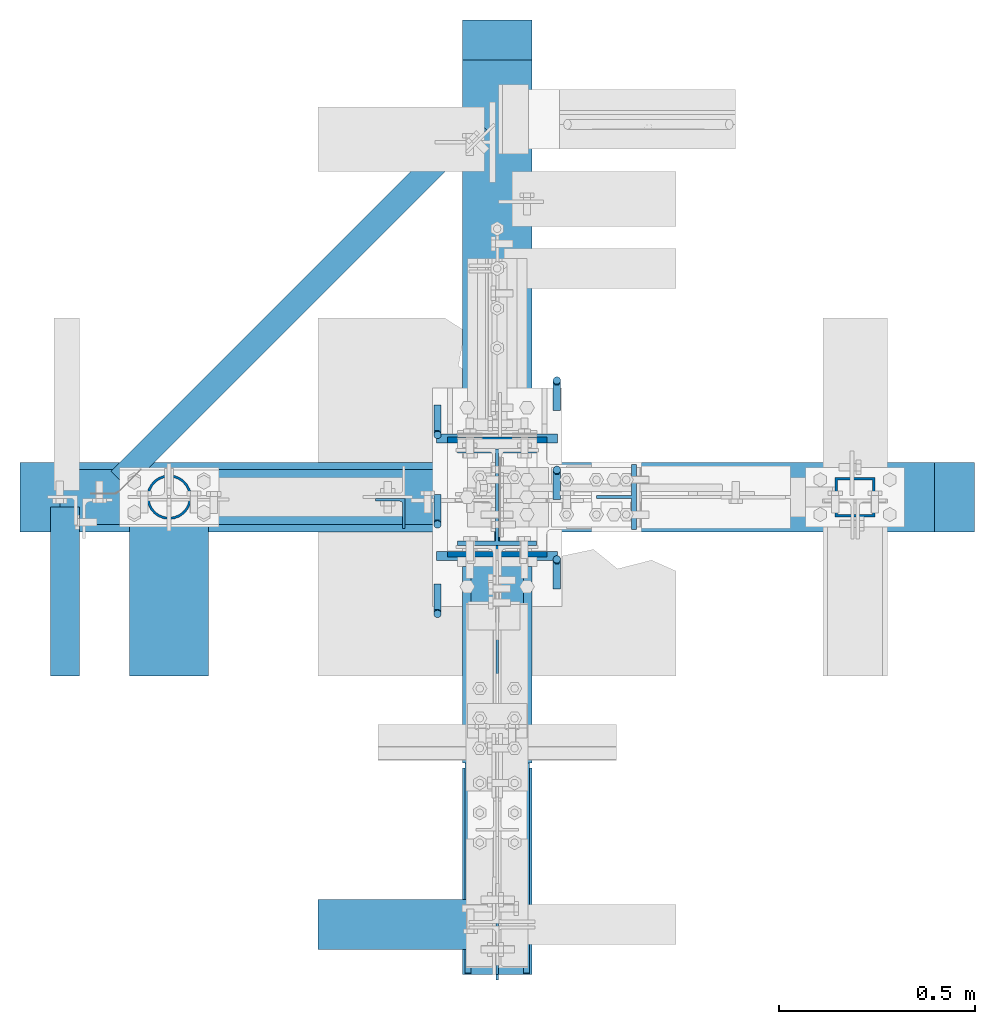
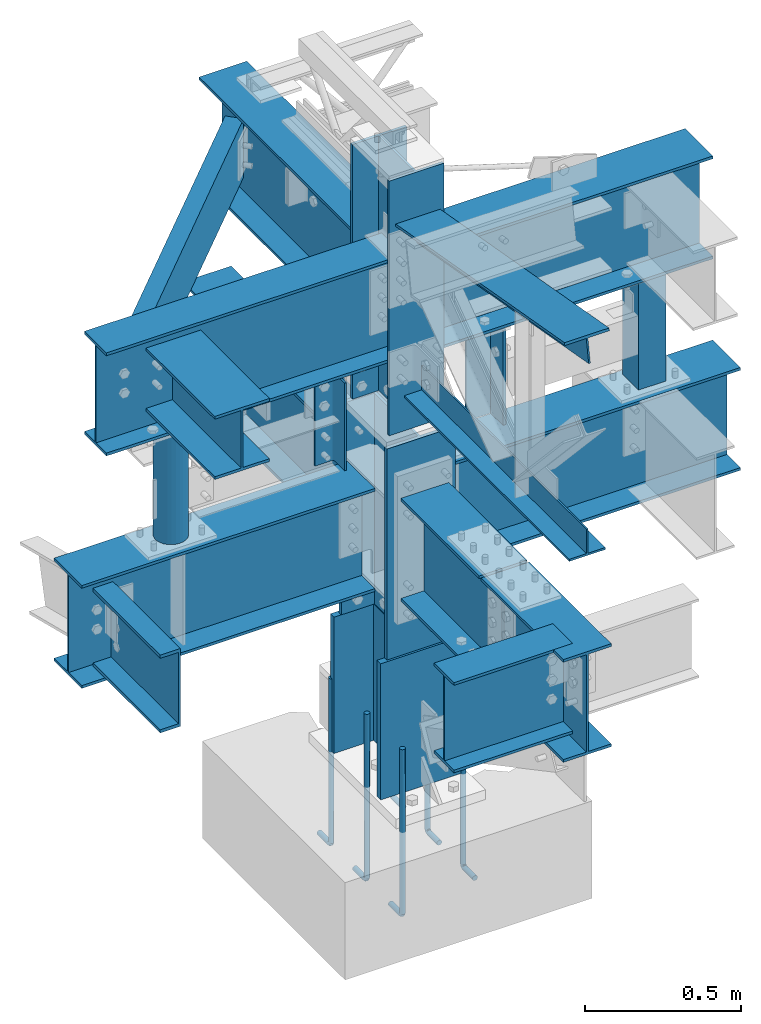
# Not in any storey, part 1 of 7: 13 columns, 12 beams, 2 members, 26 elements without a shape of their own.
"""IFC2X3 building model written with IfcOpenShell, lengths in inches."""

import ifcopenshell
import ifcopenshell.guid

model = None  # the IFC model being written
_history = None  # IfcOwnerHistory: only IFC2X3 demands one
_inside = {}  # id of a spatial element -> (the spatial element, [elements in it])
_under = {}  # id of a project, library or spatial element -> (it, [spatial elements below it])
_declared = {}  # id of a project -> (the project, [libraries it declares])
_typed = {}  # id of a type object -> (the type object, [elements of that type])
_made_of = {}  # id of a material, layer set ... -> (it, [elements and type objects made of it])


def new_model(schema):
    """Start an empty IFC model of exactly this schema.

    Asked for "IFC4X3", IfcOpenShell would pick the latest addendum, in which some entities
    have other attributes; the version numbers below select the first issue.
    IFC2X3 requires an IfcOwnerHistory on every rooted entity: one is made here for all.
    """
    global model, _history
    if schema == "IFC4X3":
        model = ifcopenshell.file(schema_version=(4, 3, 0, 0))
    else:
        model = ifcopenshell.file(schema=schema)
    _inside.clear()
    _under.clear()
    _declared.clear()
    _typed.clear()
    _made_of.clear()
    _history = None
    if model.schema == "IFC2X3":
        org = make("IfcOrganization", Name="unknown")
        user = make(
            "IfcPersonAndOrganization",
            ThePerson=make("IfcPerson", FamilyName="unknown"),
            TheOrganization=org,
        )
        app = make(
            "IfcApplication",
            ApplicationDeveloper=org,
            Version="unknown",
            ApplicationFullName="unknown",
            ApplicationIdentifier="unknown",
        )
        _history = make(
            "IfcOwnerHistory",
            OwningUser=user,
            OwningApplication=app,
            ChangeAction="ADDED",
            CreationDate=0,
        )
    return model


def make(cls, **values):
    """One entity of the class cls with the attributes given. An attribute that is None is left unset."""
    return model.create_entity(
        cls, **{name: value for name, value in values.items() if value is not None}
    )


def entity(cls, *values):
    """Any entity or typed value of the class cls, its attributes in the order of the schema. None: left unset."""
    e = model.create_entity(cls)
    for i, value in enumerate(values):
        if value is not None:
            e[i] = value
    return e


def rooted(cls, **values):
    """An entity with a GlobalId (a new one), such as an element, a storey or a relation."""
    return make(cls, GlobalId=ifcopenshell.guid.new(), OwnerHistory=_history, **values)


def si_unit(unit_type, name, prefix=None):
    """IfcSIUnit, for example si_unit("LENGTHUNIT", "METRE", prefix="MILLI")."""
    return make("IfcSIUnit", UnitType=unit_type, Prefix=prefix, Name=name)


def converted_unit(unit_type, name, factor, base, dimensions=None, offset=None):
    """IfcConversionBasedUnit, such as the inch: factor (a typed value) times the base unit."""
    return make(
        "IfcConversionBasedUnit"
        if offset is None
        else "IfcConversionBasedUnitWithOffset",
        ConversionOffset=offset,
        Dimensions=None
        if dimensions is None
        else entity("IfcDimensionalExponents", *dimensions),
        UnitType=unit_type,
        Name=name,
        ConversionFactor=make(
            "IfcMeasureWithUnit", ValueComponent=factor, UnitComponent=base
        ),
    )


def assignment(units):
    """IfcUnitAssignment: the units of a project."""
    return None if units is None else make("IfcUnitAssignment", Units=units)


def point(xyz):
    """IfcCartesianPoint."""
    return None if xyz is None else make("IfcCartesianPoint", Coordinates=xyz)


def direction(xyz):
    """IfcDirection."""
    return None if xyz is None else make("IfcDirection", DirectionRatios=xyz)


def frame(location, z_axis=None, x_axis=None):
    """IfcAxis2Placement3D, a coordinate frame: its origin and axes. An axis left out is left unset."""
    return make(
        "IfcAxis2Placement3D",
        Location=point(location),
        Axis=direction(z_axis),
        RefDirection=direction(x_axis),
    )


def frame_2d(location, x_axis=None):
    """IfcAxis2Placement2D, a coordinate frame in the plane: its origin and x axis."""
    return make(
        "IfcAxis2Placement2D", Location=point(location), RefDirection=direction(x_axis)
    )


def origin_with_axes():
    """The frame at (0, 0, 0) with the z axis (0, 0, 1) and the x axis (1, 0, 0) written out."""
    return frame((0.0, 0.0, 0.0), z_axis=(0.0, 0.0, 1.0), x_axis=(1.0, 0.0, 0.0))


def origin_2d_with_axis():
    """The frame at (0, 0) in the plane with the x axis (1, 0) written out."""
    return frame_2d((0.0, 0.0), x_axis=(1.0, 0.0))


def place(relative_to, where):
    """IfcLocalPlacement: puts the frame where relative to a parent placement (None: the world)."""
    return make(
        "IfcLocalPlacement", PlacementRelTo=relative_to, RelativePlacement=where
    )


def context(
    kind, dimensions, precision=None, world=None, true_north=None, identifier=None
):
    """IfcGeometricRepresentationContext, for example the 3D "Model" context."""
    return make(
        "IfcGeometricRepresentationContext",
        ContextIdentifier=identifier,
        ContextType=kind,
        CoordinateSpaceDimension=dimensions,
        Precision=precision,
        WorldCoordinateSystem=world,
        TrueNorth=true_north,
    )


def project(units=None, contexts=None):
    """IfcProject with its units and contexts."""
    return rooted(
        "IfcProject",
        Name="project",
        RepresentationContexts=contexts,
        UnitsInContext=assignment(units),
    )


def spatial(cls, under=None, at=None, **own):
    """A site, building, storey or space (cls), placed at a placement, below another one or the project."""
    s = rooted(cls, ObjectPlacement=at, **own)
    if under is not None:
        _under.setdefault(under.id(), (under, []))[1].append(s)
    return s


def profile(cls, at=None, kind="AREA", **sizes):
    """A parametric profile (cls). Its sizes go by their IFC names, for example OverallWidth=200.0."""
    return make(cls, ProfileType=kind, Position=at, **sizes)


def hollow_rectangle(**sizes):
    """IfcRectangleHollowProfileDef."""
    return profile("IfcRectangleHollowProfileDef", **sizes)


def hollow_circle(**sizes):
    """IfcCircleHollowProfileDef."""
    return profile("IfcCircleHollowProfileDef", **sizes)


def i_section(**sizes):
    """IfcIShapeProfileDef."""
    return profile("IfcIShapeProfileDef", **sizes)


def l_section(**sizes):
    """IfcLShapeProfileDef."""
    return profile("IfcLShapeProfileDef", **sizes)


def t_section(**sizes):
    """IfcTShapeProfileDef."""
    return profile("IfcTShapeProfileDef", **sizes)


def u_section(**sizes):
    """IfcUShapeProfileDef."""
    return profile("IfcUShapeProfileDef", **sizes)


def transform_2d(
    local_origin, x_axis=None, y_axis=None, scale=None, scale2=None, uniform=True
):
    """IfcCartesianTransformationOperator2D, or its non-uniform kind. x_axis, y_axis: its Axis1, Axis2."""
    if uniform:
        return make(
            "IfcCartesianTransformationOperator2D",
            Axis1=direction(x_axis),
            Axis2=direction(y_axis),
            LocalOrigin=point(local_origin),
            Scale=scale,
        )
    return make(
        "IfcCartesianTransformationOperator2DnonUniform",
        Axis1=direction(x_axis),
        Axis2=direction(y_axis),
        LocalOrigin=point(local_origin),
        Scale=scale,
        Scale2=scale2,
    )


def derived_profile(parent, operator, kind="AREA"):
    """IfcDerivedProfileDef: another profile, transformed."""
    return make(
        "IfcDerivedProfileDef",
        ProfileType=kind,
        ParentProfile=parent,
        Operator=operator,
    )


def extrude(swept, where, along, depth):
    """IfcExtrudedAreaSolid: the profile swept, set in the frame where, extruded along a direction by depth."""
    return make(
        "IfcExtrudedAreaSolid",
        SweptArea=swept,
        Position=where,
        ExtrudedDirection=direction(along),
        Depth=depth,
    )


def clip(a, b, op="DIFFERENCE"):
    """IfcBooleanClippingResult: the solid a cut by the half space b."""
    return make(
        "IfcBooleanClippingResult", Operator=op, FirstOperand=a, SecondOperand=b
    )


def halfspace(plane, agree):
    """IfcHalfSpaceSolid: all space on one side of the plane z = 0 of the frame plane."""
    return make(
        "IfcHalfSpaceSolid",
        BaseSurface=make("IfcPlane", Position=plane),
        AgreementFlag=agree,
    )


def shape(context_of_items, identifier, shape_type, items):
    """IfcShapeRepresentation: the items that make up one representation, for example the "Body"."""
    return make(
        "IfcShapeRepresentation",
        ContextOfItems=context_of_items,
        RepresentationIdentifier=identifier,
        RepresentationType=shape_type,
        Items=items,
    )


def source(mapping_origin, context_of_items, identifier, shape_type, items):
    """IfcRepresentationMap: a shape defined once, which mapped items show again and again."""
    return make(
        "IfcRepresentationMap",
        MappingOrigin=mapping_origin,
        MappedRepresentation=shape(context_of_items, identifier, shape_type, items),
    )


def transform(
    local_origin,
    x_axis=None,
    y_axis=None,
    z_axis=None,
    scale=None,
    scale2=None,
    scale3=None,
    uniform=True,
):
    """IfcCartesianTransformationOperator3D, or its non-uniform kind. x_axis, y_axis, z_axis: its Axis1, 2, 3."""
    if uniform:
        return make(
            "IfcCartesianTransformationOperator3D",
            Axis1=direction(x_axis),
            Axis2=direction(y_axis),
            LocalOrigin=point(local_origin),
            Scale=scale,
            Axis3=direction(z_axis),
        )
    return make(
        "IfcCartesianTransformationOperator3DnonUniform",
        Axis1=direction(x_axis),
        Axis2=direction(y_axis),
        LocalOrigin=point(local_origin),
        Scale=scale,
        Axis3=direction(z_axis),
        Scale2=scale2,
        Scale3=scale3,
    )


def mapped(mapping_source, mapping_target):
    """IfcMappedItem: shows the shape of a source again, moved by a transform."""
    return make(
        "IfcMappedItem", MappingSource=mapping_source, MappingTarget=mapping_target
    )


def material(Name=None, Category=None):
    """IfcMaterial."""
    return make("IfcMaterial", Name=Name, Category=Category)


def made_of(thing, what):
    """Note that an element or type object is made of a material, layer set ...; save() writes the relation."""
    if what is not None:
        _made_of.setdefault(what.id(), (what, []))[1].append(thing)
    return thing


def type_object(cls, material=None, **own):
    """A type object (cls), such as IfcWallType, which elements share."""
    return made_of(rooted(cls, **own), material)


def type_shapes(of_type, sources):
    """Give a type object the sources (RepresentationMaps) that its elements show as mapped items."""
    of_type.RepresentationMaps = sources


def element(
    cls,
    number,
    at=None,
    inside=None,
    cuts=None,
    type_object=None,
    material=None,
    context=None,
    identifier="Body",
    shape_type=None,
    held_by="IfcProductDefinitionShape",
    body=None,
    shapes=None,
    **own,
):
    """One element of the class cls, such as IfcWall. Its Tag is "e" and its number.

    at: its placement. inside: the storey or other place that contains it. cuts: it is an
    opening in that element (IfcRelVoidsElement). A single representation is given by context,
    identifier, shape_type and body (its items); several are given by shapes. held_by: the class
    of the entity that holds the representations. save() writes the other relations.
    """
    e = rooted(cls, Tag="e%d" % number, ObjectPlacement=at, **own)
    if body is not None:
        shapes = [shape(context, identifier, shape_type, body)]
    if shapes is not None:
        e.Representation = make(held_by, Representations=shapes)
    if inside is not None:
        _inside.setdefault(inside.id(), (inside, []))[1].append(e)
    if cuts is not None:
        rooted(
            "IfcRelVoidsElement", RelatingBuildingElement=cuts, RelatedOpeningElement=e
        )
    if type_object is not None:
        _typed.setdefault(type_object.id(), (type_object, []))[1].append(e)
    return made_of(e, material)


def aggregate(whole, parts):
    """IfcRelAggregates: a whole, such as a stair, and the parts it consists of."""
    return rooted("IfcRelAggregates", RelatingObject=whole, RelatedObjects=parts)


def save(model, path):
    """Write the relations noted so far, then the file.

    IfcRelAggregates (storeys below a building ...), IfcRelContainedInSpatialStructure (elements
    in a storey), IfcRelDefinesByType, IfcRelAssociatesMaterial and IfcRelDeclares: one each for
    every whole, place, type object, material and project.
    """
    for whole, parts in _under.values():
        aggregate(whole, parts)
    for where, things in _inside.values():
        rooted(
            "IfcRelContainedInSpatialStructure",
            RelatedElements=things,
            RelatingStructure=where,
        )
    for kind, things in _typed.values():
        rooted("IfcRelDefinesByType", RelatedObjects=things, RelatingType=kind)
    for what, things in _made_of.values():
        rooted("IfcRelAssociatesMaterial", RelatedObjects=things, RelatingMaterial=what)
    for by, libraries in _declared.values():
        rooted("IfcRelDeclares", RelatingContext=by, RelatedDefinitions=libraries)
    model.write(path)


model = new_model("IFC2X3")

# Units and contexts
model_context = context("Model", 3, precision=1e-05, world=origin_with_axes())
ifc_project = project(units=[converted_unit("LENGTHUNIT", "INCH", entity("IfcLengthMeasure", 25.4), si_unit("LENGTHUNIT", "METRE", prefix="MILLI"), dimensions=[1, 0, 0, 0, 0, 0, 0]), si_unit("PLANEANGLEUNIT", "RADIAN"), si_unit("MASSUNIT", "GRAM", prefix="KILO"), si_unit("TIMEUNIT", "SECOND"), si_unit("AREAUNIT", "SQUARE_METRE"), si_unit("PRESSUREUNIT", "PASCAL"), si_unit("FORCEUNIT", "NEWTON"), si_unit("THERMODYNAMICTEMPERATUREUNIT", "DEGREE_CELSIUS")], contexts=[model_context])

# Site, building
site_placement = place(None, origin_with_axes())
site = spatial("IfcSite", under=ifc_project, at=site_placement, CompositionType="ELEMENT")
building_placement = place(site_placement, origin_with_axes())
building = spatial("IfcBuilding", under=site, at=building_placement, Name="Building", CompositionType="ELEMENT")

# Assembly, column
assembly_1_placement = place(building_placement, frame((0.0, 0.0, -1.5), z_axis=(0.0, -1.0, 0.0), x_axis=(0.0, 0.0, 1.0)))
assembly_1 = element("IfcElementAssembly", 1, at=assembly_1_placement, inside=building, Name="1-1", PredefinedType="NOTDEFINED")
ifc_material_1 = material()
column_type_1 = type_object("IfcColumnType", Name="W12x96", PredefinedType="COLUMN", material=ifc_material_1)
shared_shape_1 = source(origin_with_axes(), model_context, "Body", "SweptSolid", [
    extrude(i_section(OverallWidth=12.16, OverallDepth=12.71, WebThickness=0.55, FlangeThickness=0.9, at=origin_2d_with_axis()), frame((0.0, 0.0, 0.0), z_axis=(1.0, 0.0, 0.0), x_axis=(0.0, 1.0, 0.0)), (0.0, 0.0, 1.0), 21.0),
])
type_shapes(column_type_1, [shared_shape_1])
column_1_placement = place(assembly_1_placement, frame((1.5, 0.0, 0.0), z_axis=(0.0, 0.0, 1.0), x_axis=(1.0, 0.0, 0.0)))
column_1 = element("IfcColumn", 2, at=column_1_placement, type_object=column_type_1, Name="w1", ObjectType="Column", context=model_context, shape_type="MappedRepresentation", body=[
    mapped(shared_shape_1, transform((0.0, 0.0, 0.0), scale=1.0)),
])
aggregate(assembly_1, [column_1])

assembly_2_placement = place(building_placement, frame((0.0, 0.0, 21.0), z_axis=(0.0, -1.0, 0.0), x_axis=(0.0, 0.0, 1.0)))
assembly_2 = element("IfcElementAssembly", 3, at=assembly_2_placement, inside=building, Name="1-2", PredefinedType="NOTDEFINED")
column_type_2 = type_object("IfcColumnType", Name="W12x53", PredefinedType="COLUMN", material=ifc_material_1)
shared_shape_2 = source(origin_with_axes(), model_context, "Body", "SweptSolid", [
    extrude(i_section(OverallWidth=9.995, OverallDepth=12.06, WebThickness=0.345, FlangeThickness=0.575, at=origin_2d_with_axis()), frame((0.0, 0.0, 0.0), z_axis=(1.0, 0.0, 0.0), x_axis=(0.0, 1.0, 0.0)), (0.0, 0.0, 1.0), 32.5),
])
type_shapes(column_type_2, [shared_shape_2])
column_2_placement = place(assembly_2_placement, origin_with_axes())
column_2 = element("IfcColumn", 4, at=column_2_placement, type_object=column_type_2, Name="w10", ObjectType="Column", context=model_context, shape_type="MappedRepresentation", body=[
    mapped(shared_shape_2, transform((0.0, 0.0, 0.0), scale=1.0)),
])
aggregate(assembly_2, [column_2])

assembly_3_placement = place(building_placement, frame((0.0, 0.0, 54.5), z_axis=(0.0, -1.0, 0.0), x_axis=(0.0, 0.0, 1.0)))
assembly_3 = element("IfcElementAssembly", 5, at=assembly_3_placement, inside=building, Name="1-3", PredefinedType="NOTDEFINED")
column_type_3 = type_object("IfcColumnType", Name="W10x33", PredefinedType="COLUMN", material=ifc_material_1)
shared_shape_3 = source(origin_with_axes(), model_context, "Body", "SweptSolid", [
    extrude(i_section(OverallWidth=7.96, OverallDepth=9.73, WebThickness=0.29, FlangeThickness=0.435, at=origin_2d_with_axis()), frame((0.0, 0.0, 0.0), z_axis=(1.0, 0.0, 0.0), x_axis=(0.0, 1.0, 0.0)), (0.0, 0.0, 1.0), 39.25),
])
type_shapes(column_type_3, [shared_shape_3])
column_3_placement = place(assembly_3_placement, origin_with_axes())
column_3 = element("IfcColumn", 6, at=column_3_placement, type_object=column_type_3, Name="w12", ObjectType="Column", context=model_context, shape_type="MappedRepresentation", body=[
    mapped(shared_shape_3, transform((0.0, 0.0, 0.0), scale=1.0)),
])
aggregate(assembly_3, [column_3])

assembly_4_placement = place(building_placement, frame((-9.25, 0.0, 50.0), z_axis=(-1.0, 0.0, 0.0), x_axis=(0.0, 0.0, 1.0)))
assembly_4 = element("IfcElementAssembly", 7, at=assembly_4_placement, inside=building, Name="4-5", PredefinedType="NOTDEFINED")
ifc_material_2 = material()
column_type_4 = type_object("IfcColumnType", Name="L3x3x1/4", PredefinedType="COLUMN", material=ifc_material_2)
shared_shape_4 = source(origin_with_axes(), model_context, "Body", "SweptSolid", [
    extrude(l_section(Depth=3.0, Width=3.0, Thickness=0.25, FilletRadius=0.3125, at=frame_2d((1.5, 1.5), x_axis=(1.0, 0.0))), frame((0.0, 0.0, 0.0), z_axis=(1.0, 0.0, 0.0), x_axis=(0.0, 1.0, 0.0)), (0.0, 0.0, 1.0), 13.5),
])
type_shapes(column_type_4, [shared_shape_4])
column_4_placement = place(assembly_4_placement, frame((0.0, -0.15625, 0.0), z_axis=(0.0, -1.0, 0.0), x_axis=(1.0, 0.0, 0.0)))
column_4 = element("IfcColumn", 8, at=column_4_placement, type_object=column_type_4, Name="a36", ObjectType="Column", context=model_context, shape_type="MappedRepresentation", body=[
    mapped(shared_shape_4, transform((0.0, 0.0, 0.0), scale=1.0)),
])
aggregate(assembly_4, [column_4])

assembly_5_placement = place(building_placement, frame((36.0, 0.0, 46.0), z_axis=(-1.0, 0.0, 0.0), x_axis=(0.0, 0.0, 1.0)))
assembly_5 = element("IfcElementAssembly", 9, at=assembly_5_placement, inside=building, Name="4-1", PredefinedType="NOTDEFINED")
ifc_material_3 = material()
column_type_5 = type_object("IfcColumnType", Name="HSS4x4x1/4", PredefinedType="COLUMN", material=ifc_material_3)
shared_shape_5 = source(origin_with_axes(), model_context, "Body", "SweptSolid", [
    extrude(hollow_rectangle(XDim=4.0, YDim=4.0, WallThickness=0.25, at=origin_2d_with_axis()), frame((0.0, 0.0, 0.0), z_axis=(1.0, 0.0, 0.0), x_axis=(0.0, 1.0, 0.0)), (0.0, 0.0, 1.0), 17.125),
])
type_shapes(column_type_5, [shared_shape_5])
column_5_placement = place(assembly_5_placement, frame((0.5, 0.0, 0.0), z_axis=(0.0, 0.0, 1.0), x_axis=(1.0, 0.0, 0.0)))
column_5 = element("IfcColumn", 10, at=column_5_placement, type_object=column_type_5, Name="ts2", ObjectType="Column", context=model_context, shape_type="MappedRepresentation", body=[
    mapped(shared_shape_5, transform((0.0, 0.0, 0.0), scale=1.0)),
])
aggregate(assembly_5, [column_5])

assembly_6_placement = place(building_placement, frame((-33.0, 0.0, 46.0), z_axis=(-1.0, 0.0, 0.0), x_axis=(0.0, 0.0, 1.0)))
assembly_6 = element("IfcElementAssembly", 11, at=assembly_6_placement, inside=building, Name="4-2", PredefinedType="NOTDEFINED")
ifc_material_4 = material()
column_type_6 = type_object("IfcColumnType", Name="PIPE-4-STD", PredefinedType="COLUMN", material=ifc_material_4)
shared_shape_6 = source(origin_with_axes(), model_context, "Body", "SweptSolid", [
    extrude(hollow_circle(Radius=2.25, WallThickness=0.237, at=origin_2d_with_axis()), frame((0.0, 0.0, 0.0), z_axis=(1.0, 0.0, 0.0), x_axis=(0.0, 1.0, 0.0)), (0.0, 0.0, 1.0), 17.125),
])
type_shapes(column_type_6, [shared_shape_6])
column_6_placement = place(assembly_6_placement, frame((0.5, 0.0, 0.0), z_axis=(0.0, 0.0, 1.0), x_axis=(1.0, 0.0, 0.0)))
column_6 = element("IfcColumn", 12, at=column_6_placement, type_object=column_type_6, Name="pp1", ObjectType="Column", context=model_context, shape_type="MappedRepresentation", body=[
    mapped(shared_shape_6, transform((0.0, 0.0, 0.0), scale=1.0)),
])
aggregate(assembly_6, [column_6])

assembly_7_placement = place(building_placement, frame((14.0, 0.0, 49.0), z_axis=(0.0, -1.0, 0.0), x_axis=(0.0, 0.0, 1.0)))
assembly_7 = element("IfcElementAssembly", 13, at=assembly_7_placement, inside=building, Name="4-4", PredefinedType="NOTDEFINED")
ifc_material_5 = material()
column_type_7 = type_object("IfcColumnType", Name="WT4x14", PredefinedType="COLUMN", material=ifc_material_5)
shared_shape_7 = source(origin_with_axes(), model_context, "Body", "SweptSolid", [
    extrude(t_section(Depth=4.03, FlangeWidth=6.535, WebThickness=0.285, FlangeThickness=0.465, at=frame_2d((0.0, -2.015), x_axis=(1.0, 0.0))), frame((0.0, 0.0, 0.0), z_axis=(1.0, 0.0, 0.0), x_axis=(0.0, 1.0, 0.0)), (0.0, 0.0, 1.0), 14.625),
])
type_shapes(column_type_7, [shared_shape_7])
column_7_placement = place(assembly_7_placement, frame((0.0, 0.0, 0.0), z_axis=(0.0, -1.0, 0.0), x_axis=(1.0, 0.0, 0.0)))
column_7 = element("IfcColumn", 14, at=column_7_placement, type_object=column_type_7, Name="wt6", ObjectType="Column", context=model_context, shape_type="MappedRepresentation", body=[
    mapped(shared_shape_7, transform((0.0, 0.0, 0.0), scale=1.0)),
])
aggregate(assembly_7, [column_7])

assembly_8_placement = place(building_placement, frame((3.0, 0.0, -22.6679382324219), z_axis=(0.0, -1.0, 0.0), x_axis=(0.0, 0.0, 1.0)))
assembly_8 = element("IfcElementAssembly", 15, at=assembly_8_placement, inside=building, Name="M_36", PredefinedType="NOTDEFINED")
column_8_placement = place(assembly_8_placement, frame((8.44018653035163, -3.0000000000418, 0.257887303829193), z_axis=(0.0, -1.0, 0.0), x_axis=(-1.0, 0.0, 0.0)))
cartesian_point_1 = entity("IfcCartesianPoint", [0.0, 0.0, 0.0])
ifc_direction_1 = entity("IfcDirection", [0.0, 0.0, 1.0])
ifc_direction_2 = entity("IfcDirection", [1.0, 0.0, 0.0])
column_8 = element("IfcColumn", 16, at=column_8_placement, Name="rb6", ObjectType="Member", context=model_context, shape_type="SweptSolid", body=[
    entity("IfcSurfaceCurveSweptAreaSolid", entity("IfcCircleProfileDef", "AREA", None, entity("IfcAxis2Placement2D", entity("IfcCartesianPoint", [0.0, 0.0]), entity("IfcDirection", [1.0, 0.0])), 0.375), entity("IfcAxis2Placement3D", cartesian_point_1, ifc_direction_1, ifc_direction_2), entity("IfcPolyline", [entity("IfcCartesianPoint", [0.2722, 0.0]), entity("IfcCartesianPoint", [0.2722, 2.5]), entity("IfcCartesianPoint", [0.234, 2.69304]), entity("IfcCartesianPoint", [0.0863, 2.88847]), entity("IfcCartesianPoint", [-0.164, 2.99645]), entity("IfcCartesianPoint", [-15.4778, 3.0])]), 0.0, 1.0, entity("IfcPlane", entity("IfcAxis2Placement3D", cartesian_point_1, ifc_direction_1, ifc_direction_2))),
])
aggregate(assembly_8, [column_8])

assembly_9_placement = place(building_placement, frame((3.0, -9.0, -22.6679382324219), z_axis=(0.0, -1.0, 0.0), x_axis=(0.0, 0.0, 1.0)))
assembly_9 = element("IfcElementAssembly", 17, at=assembly_9_placement, inside=building, Name="M_36", PredefinedType="NOTDEFINED")
column_9_placement = place(assembly_9_placement, frame((8.44018653035163, -3.0000000000418, 0.257887303829193), z_axis=(0.0, -1.0, 0.0), x_axis=(-1.0, 0.0, 0.0)))
cartesian_point_2 = entity("IfcCartesianPoint", [0.0, 0.0, 0.0])
ifc_direction_3 = entity("IfcDirection", [0.0, 0.0, 1.0])
ifc_direction_4 = entity("IfcDirection", [1.0, 0.0, 0.0])
column_9 = element("IfcColumn", 18, at=column_9_placement, Name="rb6", ObjectType="Member", context=model_context, shape_type="SweptSolid", body=[
    entity("IfcSurfaceCurveSweptAreaSolid", entity("IfcCircleProfileDef", "AREA", None, entity("IfcAxis2Placement2D", entity("IfcCartesianPoint", [0.0, 0.0]), entity("IfcDirection", [1.0, 0.0])), 0.375), entity("IfcAxis2Placement3D", cartesian_point_2, ifc_direction_3, ifc_direction_4), entity("IfcPolyline", [entity("IfcCartesianPoint", [0.2722, 0.0]), entity("IfcCartesianPoint", [0.2722, 2.5]), entity("IfcCartesianPoint", [0.234, 2.69304]), entity("IfcCartesianPoint", [0.0863, 2.88847]), entity("IfcCartesianPoint", [-0.164, 2.99645]), entity("IfcCartesianPoint", [-15.4778, 3.0])]), 0.0, 1.0, entity("IfcPlane", entity("IfcAxis2Placement3D", cartesian_point_2, ifc_direction_3, ifc_direction_4))),
])
aggregate(assembly_9, [column_9])

assembly_10_placement = place(building_placement, frame((3.0, 9.0, -22.6679382324219), z_axis=(0.0, -1.0, 0.0), x_axis=(0.0, 0.0, 1.0)))
assembly_10 = element("IfcElementAssembly", 19, at=assembly_10_placement, inside=building, Name="M_48", PredefinedType="NOTDEFINED")
column_10_placement = place(assembly_10_placement, frame((8.44018653035163, -3.0000000000418, 0.257887303829193), z_axis=(0.0, -1.0, 0.0), x_axis=(-1.0, 0.0, 0.0)))
cartesian_point_3 = entity("IfcCartesianPoint", [0.0, 0.0, 0.0])
ifc_direction_5 = entity("IfcDirection", [0.0, 0.0, 1.0])
ifc_direction_6 = entity("IfcDirection", [1.0, 0.0, 0.0])
column_10 = element("IfcColumn", 20, at=column_10_placement, Name="rb8", ObjectType="Member", context=model_context, shape_type="SweptSolid", body=[
    entity("IfcSurfaceCurveSweptAreaSolid", entity("IfcCircleProfileDef", "AREA", None, entity("IfcAxis2Placement2D", entity("IfcCartesianPoint", [0.0, 0.0]), entity("IfcDirection", [1.0, 0.0])), 0.375), entity("IfcAxis2Placement3D", cartesian_point_3, ifc_direction_5, ifc_direction_6), entity("IfcPolyline", [entity("IfcCartesianPoint", [0.2722, 0.0]), entity("IfcCartesianPoint", [0.2722, 2.5]), entity("IfcCartesianPoint", [0.234, 2.69304]), entity("IfcCartesianPoint", [0.0863, 2.88847]), entity("IfcCartesianPoint", [-0.164, 2.99645]), entity("IfcCartesianPoint", [-25.4778, 3.0])]), 0.0, 1.0, entity("IfcPlane", entity("IfcAxis2Placement3D", cartesian_point_3, ifc_direction_5, ifc_direction_6))),
])
aggregate(assembly_10, [column_10])

assembly_11_placement = place(building_placement, frame((-3.0, 0.0, -22.6679382324219), z_axis=(0.0, -1.0, 0.0), x_axis=(0.0, 0.0, 1.0)))
assembly_11 = element("IfcElementAssembly", 21, at=assembly_11_placement, inside=building, Name="M_35", PredefinedType="NOTDEFINED")
column_11_placement = place(assembly_11_placement, frame((8.44018653035163, 3.0000000000418, -0.257887303829193), z_axis=(0.0, 1.0, 0.0), x_axis=(-1.0, 0.0, 0.0)))
cartesian_point_4 = entity("IfcCartesianPoint", [0.0, 0.0, 0.0])
ifc_direction_7 = entity("IfcDirection", [0.0, 0.0, 1.0])
ifc_direction_8 = entity("IfcDirection", [1.0, 0.0, 0.0])
column_11 = element("IfcColumn", 22, at=column_11_placement, Name="rb6", ObjectType="Member", context=model_context, shape_type="SweptSolid", body=[
    entity("IfcSurfaceCurveSweptAreaSolid", entity("IfcCircleProfileDef", "AREA", None, entity("IfcAxis2Placement2D", entity("IfcCartesianPoint", [0.0, 0.0]), entity("IfcDirection", [1.0, 0.0])), 0.375), entity("IfcAxis2Placement3D", cartesian_point_4, ifc_direction_7, ifc_direction_8), entity("IfcPolyline", [entity("IfcCartesianPoint", [0.2722, 0.0]), entity("IfcCartesianPoint", [0.2722, 2.5]), entity("IfcCartesianPoint", [0.234, 2.69304]), entity("IfcCartesianPoint", [0.0863, 2.88847]), entity("IfcCartesianPoint", [-0.164, 2.99645]), entity("IfcCartesianPoint", [-25.4778, 3.0])]), 0.0, 1.0, entity("IfcPlane", entity("IfcAxis2Placement3D", cartesian_point_4, ifc_direction_7, ifc_direction_8))),
])
aggregate(assembly_11, [column_11])

assembly_12_placement = place(building_placement, frame((-3.0, -9.0, -22.6679382324219), z_axis=(0.0, -1.0, 0.0), x_axis=(0.0, 0.0, 1.0)))
assembly_12 = element("IfcElementAssembly", 23, at=assembly_12_placement, inside=building, Name="M_35", PredefinedType="NOTDEFINED")
column_12_placement = place(assembly_12_placement, frame((8.44018653035163, 3.0000000000418, -0.257887303829193), z_axis=(0.0, 1.0, 0.0), x_axis=(-1.0, 0.0, 0.0)))
cartesian_point_5 = entity("IfcCartesianPoint", [0.0, 0.0, 0.0])
ifc_direction_9 = entity("IfcDirection", [0.0, 0.0, 1.0])
ifc_direction_10 = entity("IfcDirection", [1.0, 0.0, 0.0])
column_12 = element("IfcColumn", 24, at=column_12_placement, Name="rb6", ObjectType="Member", context=model_context, shape_type="SweptSolid", body=[
    entity("IfcSurfaceCurveSweptAreaSolid", entity("IfcCircleProfileDef", "AREA", None, entity("IfcAxis2Placement2D", entity("IfcCartesianPoint", [0.0, 0.0]), entity("IfcDirection", [1.0, 0.0])), 0.375), entity("IfcAxis2Placement3D", cartesian_point_5, ifc_direction_9, ifc_direction_10), entity("IfcPolyline", [entity("IfcCartesianPoint", [0.2722, 0.0]), entity("IfcCartesianPoint", [0.2722, 2.5]), entity("IfcCartesianPoint", [0.234, 2.69304]), entity("IfcCartesianPoint", [0.0863, 2.88847]), entity("IfcCartesianPoint", [-0.164, 2.99645]), entity("IfcCartesianPoint", [-25.4778, 3.0])]), 0.0, 1.0, entity("IfcPlane", entity("IfcAxis2Placement3D", cartesian_point_5, ifc_direction_9, ifc_direction_10))),
])
aggregate(assembly_12, [column_12])

assembly_13_placement = place(building_placement, frame((-3.0, 9.0, -22.6679382324219), z_axis=(0.0, -1.0, 0.0), x_axis=(0.0, 0.0, 1.0)))
assembly_13 = element("IfcElementAssembly", 25, at=assembly_13_placement, inside=building, Name="M_50", PredefinedType="NOTDEFINED")
column_13_placement = place(assembly_13_placement, frame((8.44018653035163, 3.0000000000418, -0.257887303829193), z_axis=(0.0, 1.0, 0.0), x_axis=(-1.0, 0.0, 0.0)))
cartesian_point_6 = entity("IfcCartesianPoint", [0.0, 0.0, 0.0])
ifc_direction_11 = entity("IfcDirection", [0.0, 0.0, 1.0])
ifc_direction_12 = entity("IfcDirection", [1.0, 0.0, 0.0])
column_13 = element("IfcColumn", 26, at=column_13_placement, Name="rb8", ObjectType="Member", context=model_context, shape_type="SweptSolid", body=[
    entity("IfcSurfaceCurveSweptAreaSolid", entity("IfcCircleProfileDef", "AREA", None, entity("IfcAxis2Placement2D", entity("IfcCartesianPoint", [0.0, 0.0]), entity("IfcDirection", [1.0, 0.0])), 0.375), entity("IfcAxis2Placement3D", cartesian_point_6, ifc_direction_11, ifc_direction_12), entity("IfcPolyline", [entity("IfcCartesianPoint", [0.2722, 0.0]), entity("IfcCartesianPoint", [0.2722, 2.5]), entity("IfcCartesianPoint", [0.234, 2.69304]), entity("IfcCartesianPoint", [0.0863, 2.88847]), entity("IfcCartesianPoint", [-0.164, 2.99645]), entity("IfcCartesianPoint", [-25.4778, 3.0])]), 0.0, 1.0, entity("IfcPlane", entity("IfcAxis2Placement3D", cartesian_point_6, ifc_direction_11, ifc_direction_12))),
])
aggregate(assembly_13, [column_13])

# Assembly, beam
assembly_14_placement = place(building_placement, frame((0.0, 0.0, 46.0), z_axis=(0.0, 0.0, 1.0), x_axis=(0.0, 1.0, 0.0)))
assembly_14 = element("IfcElementAssembly", 27, at=assembly_14_placement, inside=building, Name="2-3", PredefinedType="NOTDEFINED")
beam_type_1 = type_object("IfcBeamType", Name="W16x36", PredefinedType="BEAM", material=ifc_material_1)
shared_shape_8 = source(origin_with_axes(), model_context, "Body", "SweptSolid", [
    extrude(i_section(OverallWidth=6.985, OverallDepth=15.86, WebThickness=0.295, FlangeThickness=0.43, at=frame_2d((0.0, -7.93), x_axis=(1.0, 0.0))), frame((0.0, 0.0, 0.0), z_axis=(1.0, 0.0, 0.0), x_axis=(0.0, 1.0, 0.0)), (0.0, 0.0, 1.0), 41.75),
])
type_shapes(beam_type_1, [shared_shape_8])
beam_1_placement = place(assembly_14_placement, frame((6.25, 0.0, 0.0), z_axis=(0.0, 0.0, 1.0), x_axis=(1.0, 0.0, 0.0)))
beam_1 = element("IfcBeam", 28, at=beam_1_placement, type_object=beam_type_1, Name="w19", ObjectType="Beam", context=model_context, shape_type="MappedRepresentation", body=[
    mapped(shared_shape_8, transform((0.0, 0.0, 0.0), scale=1.0)),
])
aggregate(assembly_14, [beam_1])

assembly_15_placement = place(building_placement, frame((0.0, 0.0, 46.0), z_axis=(0.0, 0.0, 1.0), x_axis=(-1.0, 0.0, 0.0)))
assembly_15 = element("IfcElementAssembly", 29, at=assembly_15_placement, inside=building, Name="2-4", PredefinedType="NOTDEFINED")
beam_type_2 = type_object("IfcBeamType", Name="W16x36", PredefinedType="BEAM", material=ifc_material_1)
shared_shape_9 = source(origin_with_axes(), model_context, "Body", "SweptSolid", [
    extrude(i_section(OverallWidth=6.985, OverallDepth=15.86, WebThickness=0.295, FlangeThickness=0.43, at=frame_2d((0.0, -7.93), x_axis=(1.0, 0.0))), frame((0.0, 0.0, 0.0), z_axis=(1.0, 0.0, 0.0), x_axis=(0.0, 1.0, 0.0)), (0.0, 0.0, 1.0), 42.75),
])
type_shapes(beam_type_2, [shared_shape_9])
beam_2_placement = place(assembly_15_placement, frame((5.25, 0.0, 0.0), z_axis=(0.0, 0.0, 1.0), x_axis=(1.0, 0.0, 0.0)))
beam_2 = element("IfcBeam", 30, at=beam_2_placement, type_object=beam_type_2, Name="w11", ObjectType="Beam", context=model_context, shape_type="MappedRepresentation", body=[
    mapped(shared_shape_9, transform((0.0, 0.0, 0.0), scale=1.0)),
])
aggregate(assembly_15, [beam_2])

assembly_16_placement = place(building_placement, frame((0.0, 0.0, 46.0), z_axis=(0.0, 0.0, 1.0), x_axis=(1.0, 0.0, 0.0)))
assembly_16 = element("IfcElementAssembly", 31, at=assembly_16_placement, inside=building, Name="2-5", PredefinedType="NOTDEFINED")
beam_type_3 = type_object("IfcBeamType", Name="W16x36", PredefinedType="BEAM", material=ifc_material_1)
shared_shape_10 = source(origin_with_axes(), model_context, "Body", "SweptSolid", [
    extrude(i_section(OverallWidth=6.985, OverallDepth=15.86, WebThickness=0.295, FlangeThickness=0.43, at=frame_2d((0.0, -7.93), x_axis=(1.0, 0.0))), frame((0.0, 0.0, 0.0), z_axis=(1.0, 0.0, 0.0), x_axis=(0.0, 1.0, 0.0)), (0.0, 0.0, 1.0), 42.5),
])
type_shapes(beam_type_3, [shared_shape_10])
beam_3_placement = place(assembly_16_placement, frame((5.5, 0.0, 0.0), z_axis=(0.0, 0.0, 1.0), x_axis=(1.0, 0.0, 0.0)))
beam_3 = element("IfcBeam", 32, at=beam_3_placement, type_object=beam_type_3, Name="w22", ObjectType="Beam", context=model_context, shape_type="MappedRepresentation", body=[
    mapped(shared_shape_10, transform((0.0, 0.0, 0.0), scale=1.0)),
])
aggregate(assembly_16, [beam_3])

assembly_17_placement = place(building_placement, frame((0.0, 0.0, 46.0), z_axis=(0.0, 0.0, 1.0), x_axis=(0.0, -1.0, 0.0)))
assembly_17 = element("IfcElementAssembly", 33, at=assembly_17_placement, inside=building, Name="2-1", PredefinedType="NOTDEFINED")
beam_type_4 = type_object("IfcBeamType", Name="W16x36", PredefinedType="BEAM", material=ifc_material_1)
shared_shape_11 = source(origin_with_axes(), model_context, "Body", "SweptSolid", [
    extrude(i_section(OverallWidth=6.985, OverallDepth=15.86, WebThickness=0.295, FlangeThickness=0.43, at=frame_2d((0.0, -7.93), x_axis=(1.0, 0.0))), frame((0.0, 0.0, 0.0), z_axis=(1.0, 0.0, 0.0), x_axis=(0.0, 1.0, 0.0)), (0.0, 0.0, 1.0), 19.75),
])
type_shapes(beam_type_4, [shared_shape_11])
beam_4_placement = place(assembly_17_placement, frame((7.0, 0.0, 0.0), z_axis=(0.0, 0.0, 1.0), x_axis=(1.0, 0.0, 0.0)))
beam_4 = element("IfcBeam", 34, at=beam_4_placement, type_object=beam_type_4, Name="w5", ObjectType="Beam", context=model_context, shape_type="MappedRepresentation", body=[
    mapped(shared_shape_11, transform((0.0, 0.0, 0.0), scale=1.0)),
])
aggregate(assembly_17, [beam_4])

assembly_18_placement = place(building_placement, frame((0.0, -27.0, 46.0), z_axis=(0.0, 0.0, 1.0), x_axis=(0.0, -1.0, 0.0)))
assembly_18 = element("IfcElementAssembly", 35, at=assembly_18_placement, inside=building, Name="2-2", PredefinedType="NOTDEFINED")
beam_type_5 = type_object("IfcBeamType", Name="W16x36", PredefinedType="BEAM", material=ifc_material_1)
shared_shape_12 = source(origin_with_axes(), model_context, "Body", "SweptSolid", [
    extrude(i_section(OverallWidth=6.985, OverallDepth=15.86, WebThickness=0.295, FlangeThickness=0.43, at=frame_2d((0.0, -7.93), x_axis=(1.0, 0.0))), frame((0.0, 0.0, 0.0), z_axis=(1.0, 0.0, 0.0), x_axis=(0.0, 1.0, 0.0)), (0.0, 0.0, 1.0), 20.75),
])
type_shapes(beam_type_5, [shared_shape_12])
beam_5_placement = place(assembly_18_placement, frame((0.25, 0.0, 0.0), z_axis=(0.0, 0.0, 1.0), x_axis=(1.0, 0.0, 0.0)))
beam_5 = element("IfcBeam", 36, at=beam_5_placement, type_object=beam_type_5, Name="w21", ObjectType="Beam", context=model_context, shape_type="MappedRepresentation", body=[
    mapped(shared_shape_12, transform((0.0, 0.0, 0.0), scale=1.0)),
])
aggregate(assembly_18, [beam_5])

assembly_19_placement = place(building_placement, frame((-42.0, 0.0, 43.0), z_axis=(0.0, 0.0, 1.0), x_axis=(0.0, -1.0, 0.0)))
assembly_19 = element("IfcElementAssembly", 37, at=assembly_19_placement, inside=building, Name="3-7", PredefinedType="NOTDEFINED")
ifc_material_6 = material()
beam_type_6 = type_object("IfcBeamType", Name="C12x20.7", PredefinedType="BEAM", material=ifc_material_6)
shared_shape_13 = source(origin_with_axes(), model_context, "Body", "SweptSolid", [
    extrude(derived_profile(u_section(Depth=12.0, FlangeWidth=2.942, WebThickness=0.282, FlangeThickness=0.501, at=frame_2d((1.471, -6.0), x_axis=(1.0, 0.0))), transform_2d((0.0, 0.0), x_axis=(-1.0, 0.0), y_axis=(0.0, 1.0))), frame((0.0, 0.0, 0.0), z_axis=(1.0, 0.0, 0.0), x_axis=(0.0, 1.0, 0.0)), (0.0, 0.0, 1.0), 17.0),
])
type_shapes(beam_type_6, [shared_shape_13])
beam_6_placement = place(assembly_19_placement, frame((18.0, 0.0, 0.0), z_axis=(0.0, 0.0, 1.0), x_axis=(-1.0, 0.0, 0.0)))
beam_6 = element("IfcBeam", 38, at=beam_6_placement, type_object=beam_type_6, Name="c6", ObjectType="Beam", context=model_context, shape_type="MappedRepresentation", body=[
    mapped(shared_shape_13, transform((0.0, 0.0, 0.0), scale=1.0)),
])
aggregate(assembly_19, [beam_6])

assembly_20_placement = place(building_placement, frame((0.0, -43.0, 46.0), z_axis=(0.0, 0.0, 1.0), x_axis=(-1.0, 0.0, 0.0)))
assembly_20 = element("IfcElementAssembly", 39, at=assembly_20_placement, inside=building, Name="3-5", PredefinedType="NOTDEFINED")
beam_type_7 = type_object("IfcBeamType", Name="W14x26", PredefinedType="BEAM", material=ifc_material_1)
shared_shape_14 = source(origin_with_axes(), model_context, "Body", "SweptSolid", [
    extrude(i_section(OverallWidth=5.025, OverallDepth=13.91, WebThickness=0.255, FlangeThickness=0.42, at=frame_2d((0.0, -6.955), x_axis=(1.0, 0.0))), frame((0.0, 0.0, 0.0), z_axis=(1.0, 0.0, 0.0), x_axis=(0.0, 1.0, 0.0)), (0.0, 0.0, 1.0), 17.3125),
])
type_shapes(beam_type_7, [shared_shape_14])
beam_7_placement = place(assembly_20_placement, frame((0.6875, 0.0, 0.0), z_axis=(0.0, 0.0, 1.0), x_axis=(1.0, 0.0, 0.0)))
beam_7 = element("IfcBeam", 40, at=beam_7_placement, type_object=beam_type_7, Name="w6", ObjectType="Beam", context=model_context, shape_type="MappedRepresentation", body=[
    mapped(shared_shape_14, transform((0.0, 0.0, 0.0), scale=1.0)),
])
aggregate(assembly_20, [beam_7])

assembly_21_placement = place(building_placement, frame((-38.0, 0.0, 77.0), z_axis=(0.0, 0.0, 1.0), x_axis=(0.707106765732237, 0.707106796640858, 0.0)))
assembly_21 = element("IfcElementAssembly", 41, at=assembly_21_placement, inside=building, Name="3-12", PredefinedType="NOTDEFINED")
beam_type_8 = type_object("IfcBeamType", Name="C9x13.4", PredefinedType="BEAM", material=ifc_material_6)
shared_shape_15 = source(origin_with_axes(), model_context, "Body", "SweptSolid", [
    extrude(u_section(Depth=9.0, FlangeWidth=2.433, WebThickness=0.233, FlangeThickness=0.413, at=frame_2d((1.2165, -4.5), x_axis=(1.0, 0.0))), frame((0.0, 0.0, 0.0), z_axis=(1.0, 0.0, 0.0), x_axis=(0.0, 1.0, 0.0)), (0.0, 0.0, 1.0), 50.9901161193848),
])
type_shapes(beam_type_8, [shared_shape_15])
beam_8_placement = place(assembly_21_placement, frame((1.25, 0.0, 0.0), z_axis=(0.0, 0.0, 1.0), x_axis=(1.0, 0.0, 0.0)))
beam_8 = element("IfcBeam", 42, at=beam_8_placement, type_object=beam_type_8, Name="c5", ObjectType="Beam", context=model_context, shape_type="MappedRepresentation", body=[
    mapped(shared_shape_15, transform((0.0, 0.0, 0.0), scale=1.0)),
])
aggregate(assembly_21, [beam_8])

assembly_22_placement = place(building_placement, frame((0.0, 0.0, 80.0), z_axis=(0.0, 0.0, 1.0), x_axis=(-1.0, 0.0, 0.0)))
assembly_22 = element("IfcElementAssembly", 43, at=assembly_22_placement, inside=building, Name="2-7", PredefinedType="NOTDEFINED")
beam_type_9 = type_object("IfcBeamType", Name="W16x31", PredefinedType="BEAM", material=ifc_material_1)
shared_shape_16 = source(origin_with_axes(), model_context, "Body", "SweptSolid", [
    extrude(i_section(OverallWidth=5.525, OverallDepth=15.88, WebThickness=0.275, FlangeThickness=0.44, at=frame_2d((0.0, -7.94), x_axis=(1.0, 0.0))), frame((0.0, 0.0, 0.0), z_axis=(1.0, 0.0, 0.0), x_axis=(0.0, 1.0, 0.0)), (0.0, 0.0, 1.0), 43.3125),
])
type_shapes(beam_type_9, [shared_shape_16])
beam_9_placement = place(assembly_22_placement, frame((0.6875, 0.0, 0.0), z_axis=(0.0, 0.0, 1.0), x_axis=(1.0, 0.0, 0.0)))
beam_9 = element("IfcBeam", 44, at=beam_9_placement, type_object=beam_type_9, Name="w20", ObjectType="Beam", context=model_context, shape_type="MappedRepresentation", body=[
    mapped(shared_shape_16, transform((0.0, 0.0, 0.0), scale=1.0)),
])
aggregate(assembly_22, [beam_9])

assembly_23_placement = place(building_placement, frame((0.0, 0.0, 80.0), z_axis=(0.0, 0.0, 1.0), x_axis=(0.0, 1.0, 0.0)))
assembly_23 = element("IfcElementAssembly", 45, at=assembly_23_placement, inside=building, Name="2-6", PredefinedType="NOTDEFINED")
beam_type_10 = type_object("IfcBeamType", Name="W16x36", PredefinedType="BEAM", material=ifc_material_1)
shared_shape_17 = source(origin_with_axes(), model_context, "Body", "SweptSolid", [
    extrude(i_section(OverallWidth=6.985, OverallDepth=15.86, WebThickness=0.295, FlangeThickness=0.43, at=frame_2d((0.0, -7.93), x_axis=(1.0, 0.0))), frame((0.0, 0.0, 0.0), z_axis=(1.0, 0.0, 0.0), x_axis=(0.0, 1.0, 0.0)), (0.0, 0.0, 1.0), 38.625),
])
type_shapes(beam_type_10, [shared_shape_17])
beam_10_placement = place(assembly_23_placement, frame((5.375, 0.0, 0.0), z_axis=(0.0, 0.0, 1.0), x_axis=(1.0, 0.0, 0.0)))
beam_10 = element("IfcBeam", 46, at=beam_10_placement, type_object=beam_type_10, Name="w7", ObjectType="Beam", context=model_context, shape_type="MappedRepresentation", body=[
    mapped(shared_shape_17, transform((0.0, 0.0, 0.0), scale=1.0)),
])
aggregate(assembly_23, [beam_10])

assembly_24_placement = place(building_placement, frame((0.0, 0.0, 80.0), z_axis=(0.0, 0.0, 1.0), x_axis=(1.0, 0.0, 0.0)))
assembly_24 = element("IfcElementAssembly", 47, at=assembly_24_placement, inside=building, Name="2-8", PredefinedType="NOTDEFINED")
beam_type_11 = type_object("IfcBeamType", Name="W16x36", PredefinedType="BEAM", material=ifc_material_1)
shared_shape_18 = source(origin_with_axes(), model_context, "Body", "SweptSolid", [
    extrude(i_section(OverallWidth=6.985, OverallDepth=15.86, WebThickness=0.295, FlangeThickness=0.43, at=frame_2d((0.0, -7.93), x_axis=(1.0, 0.0))), frame((0.0, 0.0, 0.0), z_axis=(1.0, 0.0, 0.0), x_axis=(0.0, 1.0, 0.0)), (0.0, 0.0, 1.0), 43.0),
])
type_shapes(beam_type_11, [shared_shape_18])
beam_11_placement = place(assembly_24_placement, frame((1.0, 0.0, 0.0), z_axis=(0.0, 0.0, 1.0), x_axis=(1.0, 0.0, 0.0)))
beam_11 = element("IfcBeam", 48, at=beam_11_placement, type_object=beam_type_11, Name="w14", ObjectType="Beam", context=model_context, shape_type="MappedRepresentation", body=[
    mapped(shared_shape_18, transform((0.0, 0.0, 0.0), scale=1.0)),
])
aggregate(assembly_24, [beam_11])

assembly_25_placement = place(building_placement, frame((-33.0, 0.0, 77.0), z_axis=(0.0, 0.0, 1.0), x_axis=(0.0, -1.0, 0.0)))
assembly_25 = element("IfcElementAssembly", 49, at=assembly_25_placement, inside=building, Name="3-10", PredefinedType="NOTDEFINED")
beam_type_12 = type_object("IfcBeamType", Name="W10x33", PredefinedType="BEAM", material=ifc_material_1)
shared_shape_19 = source(origin_with_axes(), model_context, "Body", "SweptSolid", [
    extrude(i_section(OverallWidth=7.96, OverallDepth=9.73, WebThickness=0.29, FlangeThickness=0.435, at=frame_2d((0.0, -4.865), x_axis=(1.0, 0.0))), frame((0.0, 0.0, 0.0), z_axis=(1.0, 0.0, 0.0), x_axis=(0.0, 1.0, 0.0)), (0.0, 0.0, 1.0), 17.375),
])
type_shapes(beam_type_12, [shared_shape_19])
beam_12_placement = place(assembly_25_placement, frame((0.625, 0.0, 0.0), z_axis=(0.0, 0.0, 1.0), x_axis=(1.0, 0.0, 0.0)))
beam_12 = element("IfcBeam", 50, at=beam_12_placement, type_object=beam_type_12, Name="w9", ObjectType="Beam", context=model_context, shape_type="MappedRepresentation", body=[
    mapped(shared_shape_19, transform((0.0, 0.0, 0.0), scale=1.0)),
])
aggregate(assembly_25, [beam_12])

# Assembly, members
assembly_26_placement = place(building_placement, frame((0.0, -47.9999999999999, 94.0), z_axis=(0.0, 0.17437043319647, 0.984680126755321), x_axis=(0.0, 0.98468012675532, -0.17437043319647)))
assembly_26 = element("IfcElementAssembly", 51, at=assembly_26_placement, inside=building, Name="4-8", PredefinedType="NOTDEFINED")
member_type_1 = type_object("IfcMemberType", Name="WT4x9", PredefinedType="USERDEFINED", material=ifc_material_5)
shared_shape_20 = source(origin_with_axes(), model_context, "Body", "SweptSolid", [
    extrude(t_section(Depth=4.07, FlangeWidth=5.25, WebThickness=0.23, FlangeThickness=0.33, at=frame_2d((0.0, -2.035), x_axis=(1.0, 0.0))), frame((0.0, 0.0, 0.0), z_axis=(1.0, 0.0, 0.0), x_axis=(0.0, 1.0, 0.0)), (0.0, 0.0, 1.0), 41.625),
])
type_shapes(member_type_1, [shared_shape_20])
member_1_placement = place(assembly_26_placement, frame((5.78691875170775, 0.0, -32.6790717066922), z_axis=(0.17437043319647, 0.0, -0.984680126755321), x_axis=(0.98468012675532, 0.0, 0.17437043319647)))
member_1 = element("IfcMember", 52, at=member_1_placement, type_object=member_type_1, Name="wt2", ObjectType="Beam", context=model_context, shape_type="MappedRepresentation", body=[
    mapped(shared_shape_20, transform((0.0, 0.0, 0.0), scale=1.0)),
])
member_type_2 = type_object("IfcMemberType", Name="WT4x12", PredefinedType="USERDEFINED", material=ifc_material_5)
shared_shape_21 = source(origin_with_axes(), model_context, "Body", "Clipping", [
    clip(extrude(t_section(Depth=3.965, FlangeWidth=6.495, WebThickness=0.245, FlangeThickness=0.4, at=frame_2d((0.0, -1.9825), x_axis=(1.0, 0.0))), frame((0.0, 0.0, 0.0), z_axis=(1.0, 0.0, 0.0), x_axis=(0.0, 1.0, 0.0)), (0.0, 0.0, 1.0), 44.0114288330078), halfspace(frame((44.0114288330078, 0.0, -3.965), z_axis=(0.98469, 0.0, 0.17434), x_axis=(-0.17434, 0.0, 0.98469)), False)),
])
type_shapes(member_type_2, [shared_shape_21])
member_2_placement = place(assembly_26_placement, frame((0.0, 0.0, 0.687500208160444), z_axis=(0.0, 0.0, 1.0), x_axis=(1.0, 0.0, 0.0)))
member_2 = element("IfcMember", 53, at=member_2_placement, type_object=member_type_2, Name="wt4", ObjectType="Beam", context=model_context, shape_type="MappedRepresentation", body=[
    mapped(shared_shape_21, transform((0.0, 0.0, 0.0), scale=1.0)),
])
aggregate(assembly_26, [member_1, member_2])

save(model, "model.ifc")
